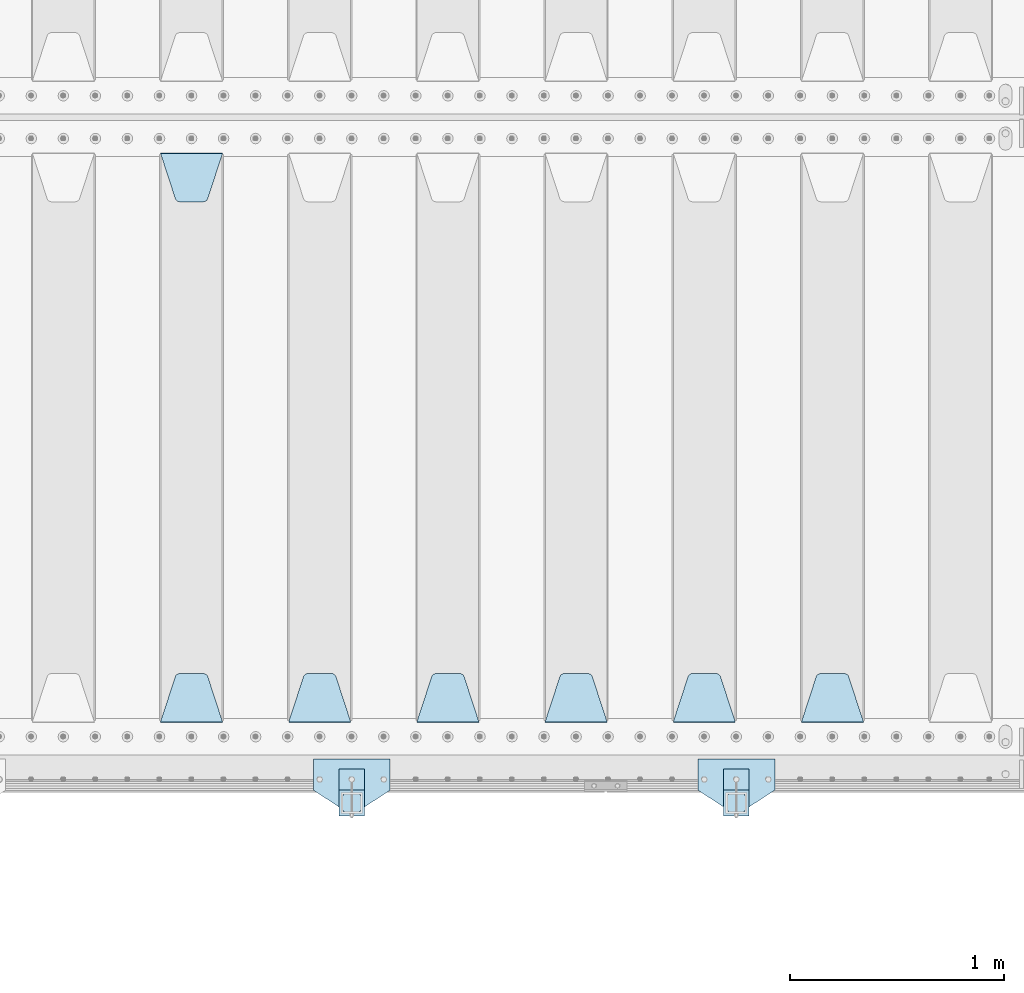
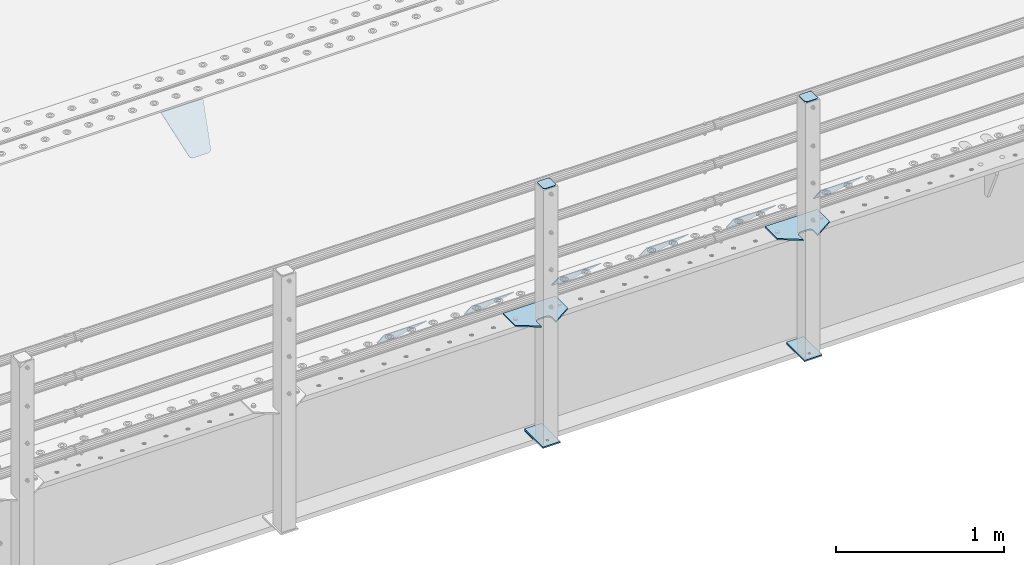
# One storey, part 197 of 242: 15 plates.
"""IFC2X3 building model written with IfcOpenShell, lengths in millimetres."""

from ifc_helpers import new_model, si_unit, frame, origin_with_axes, place, context, subcontext, project, spatial, faceted_brep, material, type_object, element, save


model = new_model("IFC2X3")

# Units and contexts
model_context = context("Model", 3, precision=1e-05, world=origin_with_axes())
body_context = subcontext(model_context, "Body", "Model", "MODEL_VIEW")
ifc_project = project(units=[si_unit("LENGTHUNIT", "METRE", prefix="MILLI"), si_unit("AREAUNIT", "SQUARE_METRE"), si_unit("VOLUMEUNIT", "CUBIC_METRE"), si_unit("MASSUNIT", "GRAM", prefix="KILO"), si_unit("TIMEUNIT", "SECOND"), si_unit("PLANEANGLEUNIT", "RADIAN"), si_unit("SOLIDANGLEUNIT", "STERADIAN"), si_unit("THERMODYNAMICTEMPERATUREUNIT", "DEGREE_CELSIUS"), si_unit("LUMINOUSINTENSITYUNIT", "LUMEN")], contexts=[model_context])

# Site, building, storey
site_placement = place(None, origin_with_axes())
site = spatial("IfcSite", under=ifc_project, at=site_placement, CompositionType="ELEMENT")
building_placement = place(site_placement, origin_with_axes())
building = spatial("IfcBuilding", under=site, at=building_placement, Name="Standard", CompositionType="ELEMENT")
storey_placement = place(building_placement, origin_with_axes())
storey = spatial("IfcBuildingStorey", under=building, at=storey_placement, Name="Undefined", CompositionType="ELEMENT", Elevation=0.0)

# Plates
ifc_material_1 = material(Name="STEEL/S355J2")
plate_type_1 = type_object("IfcPlateType", PredefinedType="NOTDEFINED")
plate_1_placement = place(storey_placement, frame((-36320.0, -24005.0, 5.00000000004911), z_axis=(0.0, -1.0, 0.0), x_axis=(-1.0, 0.0, 0.0)))
element("IfcPlate", 1, at=plate_1_placement, inside=storey, type_object=plate_type_1, material=ifc_material_1, context=body_context, shape_type="Brep", body=[
    faceted_brep([(0.0, -5.0, 0.0), (2.31396552408114e-06, -5.0, 145.0), (2.31396552408114e-06, 5.0, 145.0), (0.0, 5.0, 0.0), (130.0, -5.0, 230.0), (130.0, 5.0, 230.0), (130.0, -5.0, 180.0), (130.0, 5.0, 180.0), (130.48036798992, -5.0, 175.122741949595), (130.48036798992, 5.0, 175.122741949595), (131.903011687216, -5.0, 170.432914190871), (131.903011687216, 5.0, 170.432914190871), (134.213259692435, -5.0, 166.110744174512), (134.213259692435, 5.0, 166.110744174512), (137.322330470335, -5.0, 162.322330470335), (137.322330470335, 5.0, 162.322330470335), (141.110744174512, -5.0, 159.213259692435), (141.110744174512, 5.0, 159.213259692435), (145.432914190871, -5.0, 156.903011687216), (145.432914190871, 5.0, 156.903011687216), (150.122741949595, -5.0, 155.48036798992), (150.122741949595, 5.0, 155.48036798992), (155.0, -5.0, 155.0), (155.0, 5.0, 155.0), (205.0, -5.0, 155.0), (205.0, 5.0, 155.0), (209.877258050405, -5.0, 155.48036798992), (209.877258050405, 5.0, 155.48036798992), (214.567085809129, -5.0, 156.903011687216), (214.567085809129, 5.0, 156.903011687216), (218.889255825488, -5.0, 159.213259692435), (218.889255825488, 5.0, 159.213259692435), (222.677669529665, -5.0, 162.322330470335), (222.677669529665, 5.0, 162.322330470335), (225.786740307565, -5.0, 166.110744174512), (225.786740307565, 5.0, 166.110744174512), (228.096988312784, -5.0, 170.432914190871), (228.096988312784, 5.0, 170.432914190871), (229.51963201008, -5.0, 175.122741949595), (229.51963201008, 5.0, 175.122741949595), (230.0, -5.0, 180.0), (230.0, 5.0, 180.0), (230.0, -5.0, 230.0), (230.0, 5.0, 230.0), (360.0, -5.0, 145.0), (360.0, 5.0, 145.0), (360.0, -5.0, -7.27595761418343e-12), (360.0, 5.0, -7.27595761418343e-12)], [[[0, 1, 2, 3]], [[1, 4, 5, 2]], [[4, 6, 7, 5]], [[6, 8, 9, 7]], [[8, 10, 11, 9]], [[10, 12, 13, 11]], [[12, 14, 15, 13]], [[14, 16, 17, 15]], [[16, 18, 19, 17]], [[18, 20, 21, 19]], [[20, 22, 23, 21]], [[22, 24, 25, 23]], [[24, 26, 27, 25]], [[26, 28, 29, 27]], [[28, 30, 31, 29]], [[30, 32, 33, 31]], [[32, 34, 35, 33]], [[34, 36, 37, 35]], [[36, 38, 39, 37]], [[38, 40, 41, 39]], [[40, 42, 43, 41]], [[42, 44, 45, 43]], [[44, 46, 47, 45]], [[46, 0, 3, 47]], [[5, 7, 9, 11, 13, 15, 17, 19, 21, 23, 25, 27, 29, 31, 33, 35, 37, 39, 41, 43, 45, 47, 3, 2]], [[46, 44, 42, 40, 38, 36, 34, 32, 30, 28, 26, 24, 22, 20, 18, 16, 14, 12, 10, 8, 6, 4, 1, 0]]]),
])
plate_2_placement = place(storey_placement, frame((-38120.0, -24005.0, 5.00000000004911), z_axis=(0.0, -1.0, 0.0), x_axis=(-1.0, 0.0, 0.0)))
element("IfcPlate", 2, at=plate_2_placement, inside=storey, type_object=plate_type_1, material=ifc_material_1, context=body_context, shape_type="Brep", body=[
    faceted_brep([(0.0, -5.0, 0.0), (2.31396552408114e-06, -5.0, 145.0), (2.31396552408114e-06, 5.0, 145.0), (0.0, 5.0, 0.0), (130.0, -5.0, 230.0), (130.0, 5.0, 230.0), (130.0, -5.0, 180.0), (130.0, 5.0, 180.0), (130.48036798992, -5.0, 175.122741949595), (130.48036798992, 5.0, 175.122741949595), (131.903011687216, -5.0, 170.432914190871), (131.903011687216, 5.0, 170.432914190871), (134.213259692435, -5.0, 166.110744174512), (134.213259692435, 5.0, 166.110744174512), (137.322330470335, -5.0, 162.322330470335), (137.322330470335, 5.0, 162.322330470335), (141.110744174512, -5.0, 159.213259692435), (141.110744174512, 5.0, 159.213259692435), (145.432914190871, -5.0, 156.903011687216), (145.432914190871, 5.0, 156.903011687216), (150.122741949595, -5.0, 155.48036798992), (150.122741949595, 5.0, 155.48036798992), (155.0, -5.0, 155.0), (155.0, 5.0, 155.0), (205.0, -5.0, 155.0), (205.0, 5.0, 155.0), (209.877258050405, -5.0, 155.48036798992), (209.877258050405, 5.0, 155.48036798992), (214.567085809129, -5.0, 156.903011687216), (214.567085809129, 5.0, 156.903011687216), (218.889255825488, -5.0, 159.213259692435), (218.889255825488, 5.0, 159.213259692435), (222.677669529665, -5.0, 162.322330470335), (222.677669529665, 5.0, 162.322330470335), (225.786740307565, -5.0, 166.110744174512), (225.786740307565, 5.0, 166.110744174512), (228.096988312784, -5.0, 170.432914190871), (228.096988312784, 5.0, 170.432914190871), (229.51963201008, -5.0, 175.122741949595), (229.51963201008, 5.0, 175.122741949595), (230.0, -5.0, 180.0), (230.0, 5.0, 180.0), (230.0, -5.0, 230.0), (230.0, 5.0, 230.0), (360.0, -5.0, 145.0), (360.0, 5.0, 145.0), (360.0, -5.0, -7.27595761418343e-12), (360.0, 5.0, -7.27595761418343e-12)], [[[0, 1, 2, 3]], [[1, 4, 5, 2]], [[4, 6, 7, 5]], [[6, 8, 9, 7]], [[8, 10, 11, 9]], [[10, 12, 13, 11]], [[12, 14, 15, 13]], [[14, 16, 17, 15]], [[16, 18, 19, 17]], [[18, 20, 21, 19]], [[20, 22, 23, 21]], [[22, 24, 25, 23]], [[24, 26, 27, 25]], [[26, 28, 29, 27]], [[28, 30, 31, 29]], [[30, 32, 33, 31]], [[32, 34, 35, 33]], [[34, 36, 37, 35]], [[36, 38, 39, 37]], [[38, 40, 41, 39]], [[40, 42, 43, 41]], [[42, 44, 45, 43]], [[44, 46, 47, 45]], [[46, 0, 3, 47]], [[5, 7, 9, 11, 13, 15, 17, 19, 21, 23, 25, 27, 29, 31, 33, 35, 37, 39, 41, 43, 45, 47, 3, 2]], [[46, 44, 42, 40, 38, 36, 34, 32, 30, 28, 26, 24, 22, 20, 18, 16, 14, 12, 10, 8, 6, 4, 1, 0]]]),
])
plate_type_2 = type_object("IfcPlateType", PredefinedType="NOTDEFINED")
for number, where, z_axis, x_axis in (
    (3, (-36440.0000000001, -24050.0000000002, -850.000000000002), (0.0, -1.0, 0.0), (-1.0, 0.0, 0.0)),
    (4, (-38240.0000000001, -24050.0000000002, -850.000000000002), (0.0, -1.0, 0.0), (-1.0, 0.0, 0.0)),
):
    element("IfcPlate", number, at=place(storey_placement, frame(where, z_axis=z_axis, x_axis=x_axis)), inside=storey, type_object=plate_type_2, material=ifc_material_1, context=body_context, shape_type="Brep", body=[
        faceted_brep([(53.6360389691836, -5.0, 176.363961030471), (53.6360389691836, 5.0, 176.363961030471), (59.9999999998618, 5.0, 178.999999999793), (59.9999999998618, -5.0, 178.999999999793), (66.3639610305399, 5.0, 176.363961030471), (66.3639610305399, -5.0, 176.363961030471), (68.9999999998618, 5.0, 169.999999999793), (68.9999999998618, -5.0, 169.999999999793), (66.3639610305399, 5.0, 163.636038969114), (66.3639610305399, -5.0, 163.636038969114), (59.9999999998618, 5.0, 160.999999999793), (59.9999999998618, -5.0, 160.999999999793), (53.6360389691836, 5.0, 163.636038969114), (53.6360389691836, -5.0, 163.636038969114), (50.9999999998618, 5.0, 169.999999999793), (50.9999999998618, -5.0, 169.999999999793), (120.0, -5.0, 0.0), (120.0, -5.0, 220.0), (0.0, -5.0, 220.0), (0.0, -5.0, 0.0), (0.0, 5.0, 0.0), (120.0, 5.0, 0.0), (120.0, 5.0, 220.0), (0.0, 5.0, 220.0)], [[[0, 1, 2, 3]], [[3, 2, 4, 5]], [[5, 4, 6, 7]], [[7, 6, 8, 9]], [[9, 8, 10, 11]], [[11, 10, 12, 13]], [[13, 12, 14, 15]], [[15, 14, 1, 0]], [[16, 17, 18, 19], [3, 5, 7, 9, 11, 13, 15, 0]], [[16, 19, 20, 21]], [[17, 16, 21, 22]], [[18, 17, 22, 23]], [[19, 18, 23, 20]], [[22, 21, 20, 23], [10, 8, 6, 4, 2, 1, 14, 12]]]),
    ])
plate_type_3 = type_object("IfcPlateType", PredefinedType="NOTDEFINED")
plate_3_placement = place(storey_placement, frame((-36544.0000000001, -24166.0000000002, 1012.50000000001), z_axis=(0.0, -1.0, 0.0), x_axis=(1.0, 0.0, 0.0)))
element("IfcPlate", 5, at=plate_3_placement, inside=storey, type_object=plate_type_3, material=ifc_material_1, context=body_context, shape_type="Brep", body=[
    faceted_brep([(0.0, -2.5, 19.0), (0.0, -2.5, 69.0), (0.0, 2.5, 69.0), (0.0, 2.5, 19.0), (0.476369668544066, -2.5, 73.2278977451715), (0.476369668544066, 2.5, 73.2278977451715), (1.88159150985302, -2.5, 77.2437910432345), (1.88159150985302, 2.5, 77.2437910432345), (4.14520183310742, -2.5, 80.8463062353148), (4.14520183310742, 2.5, 80.8463062353148), (7.15369376468516, -2.5, 83.8547981668926), (7.15369376468516, 2.5, 83.8547981668926), (10.7562089567655, -2.5, 86.118408490147), (10.7562089567655, 2.5, 86.118408490147), (14.7721022548285, -2.5, 87.5236303314559), (14.7721022548285, 2.5, 87.5236303314559), (19.0, -2.5, 88.0), (19.0, 2.5, 88.0), (69.0, -2.5, 88.0), (69.0, 2.5, 88.0), (73.2278977451715, -2.5, 87.5236303314559), (73.2278977451715, 2.5, 87.5236303314559), (77.2437910432345, -2.5, 86.118408490147), (77.2437910432345, 2.5, 86.118408490147), (80.8463062353148, -2.5, 83.8547981668926), (80.8463062353148, 2.5, 83.8547981668926), (83.8547981668926, -2.5, 80.8463062353148), (83.8547981668926, 2.5, 80.8463062353148), (86.118408490147, -2.5, 77.2437910432345), (86.118408490147, 2.5, 77.2437910432345), (87.5236303314559, -2.5, 73.2278977451715), (87.5236303314559, 2.5, 73.2278977451715), (88.0, -2.5, 69.0), (88.0, 2.5, 69.0), (88.0, -2.5, 19.0), (88.0, 2.5, 19.0), (87.5236303314559, -2.5, 14.7721022548285), (87.5236303314559, 2.5, 14.7721022548285), (86.118408490147, -2.5, 10.7562089567655), (86.118408490147, 2.5, 10.7562089567655), (83.8547981668926, -2.5, 7.15369376468516), (83.8547981668926, 2.5, 7.15369376468516), (80.8463062353148, -2.5, 4.14520183310742), (80.8463062353148, 2.5, 4.14520183310742), (77.2437910432345, -2.5, 1.88159150985302), (77.2437910432345, 2.5, 1.88159150985302), (73.2278977451715, -2.5, 0.476369668544066), (73.2278977451715, 2.5, 0.476369668544066), (69.0, -2.5, 0.0), (69.0, 2.5, 0.0), (19.0, -2.5, 0.0), (19.0, 2.5, 0.0), (14.7721022548285, -2.5, 0.476369668544066), (14.7721022548285, 2.5, 0.476369668544066), (10.7562089567655, -2.5, 1.88159150985302), (10.7562089567655, 2.5, 1.88159150985302), (7.15369376468516, -2.5, 4.14520183310742), (7.15369376468516, 2.5, 4.14520183310742), (4.14520183310742, -2.5, 7.15369376468516), (4.14520183310742, 2.5, 7.15369376468516), (1.88159150985302, -2.5, 10.7562089567655), (1.88159150985302, 2.5, 10.7562089567655), (0.476369668544066, -2.5, 14.7721022548285), (0.476369668544066, 2.5, 14.7721022548285)], [[[0, 1, 2, 3]], [[1, 4, 5, 2]], [[4, 6, 7, 5]], [[6, 8, 9, 7]], [[8, 10, 11, 9]], [[10, 12, 13, 11]], [[12, 14, 15, 13]], [[14, 16, 17, 15]], [[16, 18, 19, 17]], [[18, 20, 21, 19]], [[20, 22, 23, 21]], [[22, 24, 25, 23]], [[24, 26, 27, 25]], [[26, 28, 29, 27]], [[28, 30, 31, 29]], [[30, 32, 33, 31]], [[32, 34, 35, 33]], [[34, 36, 37, 35]], [[36, 38, 39, 37]], [[38, 40, 41, 39]], [[40, 42, 43, 41]], [[42, 44, 45, 43]], [[44, 46, 47, 45]], [[46, 48, 49, 47]], [[48, 50, 51, 49]], [[50, 52, 53, 51]], [[52, 54, 55, 53]], [[54, 56, 57, 55]], [[56, 58, 59, 57]], [[58, 60, 61, 59]], [[60, 62, 63, 61]], [[62, 0, 3, 63]], [[5, 7, 9, 11, 13, 15, 17, 19, 21, 23, 25, 27, 29, 31, 33, 35, 37, 39, 41, 43, 45, 47, 49, 51, 53, 55, 57, 59, 61, 63, 3, 2]], [[62, 60, 58, 56, 54, 52, 50, 48, 46, 44, 42, 40, 38, 36, 34, 32, 30, 28, 26, 24, 22, 20, 18, 16, 14, 12, 10, 8, 6, 4, 1, 0]]]),
])
plate_4_placement = place(storey_placement, frame((-38344.0000000001, -24166.0000000002, 1012.50000000001), z_axis=(0.0, -1.0, 0.0), x_axis=(1.0, 0.0, 0.0)))
element("IfcPlate", 6, at=plate_4_placement, inside=storey, type_object=plate_type_3, material=ifc_material_1, context=body_context, shape_type="Brep", body=[
    faceted_brep([(0.0, -2.5, 19.0), (0.0, -2.5, 69.0), (0.0, 2.5, 69.0), (0.0, 2.5, 19.0), (0.476369668544066, -2.5, 73.2278977451715), (0.476369668544066, 2.5, 73.2278977451715), (1.88159150985302, -2.5, 77.2437910432345), (1.88159150985302, 2.5, 77.2437910432345), (4.14520183310742, -2.5, 80.8463062353148), (4.14520183310742, 2.5, 80.8463062353148), (7.15369376468516, -2.5, 83.8547981668926), (7.15369376468516, 2.5, 83.8547981668926), (10.7562089567655, -2.5, 86.118408490147), (10.7562089567655, 2.5, 86.118408490147), (14.7721022548285, -2.5, 87.5236303314559), (14.7721022548285, 2.5, 87.5236303314559), (19.0, -2.5, 88.0), (19.0, 2.5, 88.0), (69.0, -2.5, 88.0), (69.0, 2.5, 88.0), (73.2278977451715, -2.5, 87.5236303314559), (73.2278977451715, 2.5, 87.5236303314559), (77.2437910432345, -2.5, 86.118408490147), (77.2437910432345, 2.5, 86.118408490147), (80.8463062353148, -2.5, 83.8547981668926), (80.8463062353148, 2.5, 83.8547981668926), (83.8547981668926, -2.5, 80.8463062353148), (83.8547981668926, 2.5, 80.8463062353148), (86.118408490147, -2.5, 77.2437910432345), (86.118408490147, 2.5, 77.2437910432345), (87.5236303314559, -2.5, 73.2278977451715), (87.5236303314559, 2.5, 73.2278977451715), (88.0, -2.5, 69.0), (88.0, 2.5, 69.0), (88.0, -2.5, 19.0), (88.0, 2.5, 19.0), (87.5236303314559, -2.5, 14.7721022548285), (87.5236303314559, 2.5, 14.7721022548285), (86.118408490147, -2.5, 10.7562089567655), (86.118408490147, 2.5, 10.7562089567655), (83.8547981668926, -2.5, 7.15369376468516), (83.8547981668926, 2.5, 7.15369376468516), (80.8463062353148, -2.5, 4.14520183310742), (80.8463062353148, 2.5, 4.14520183310742), (77.2437910432345, -2.5, 1.88159150985302), (77.2437910432345, 2.5, 1.88159150985302), (73.2278977451715, -2.5, 0.476369668544066), (73.2278977451715, 2.5, 0.476369668544066), (69.0, -2.5, 0.0), (69.0, 2.5, 0.0), (19.0, -2.5, 0.0), (19.0, 2.5, 0.0), (14.7721022548285, -2.5, 0.476369668544066), (14.7721022548285, 2.5, 0.476369668544066), (10.7562089567655, -2.5, 1.88159150985302), (10.7562089567655, 2.5, 1.88159150985302), (7.15369376468516, -2.5, 4.14520183310742), (7.15369376468516, 2.5, 4.14520183310742), (4.14520183310742, -2.5, 7.15369376468516), (4.14520183310742, 2.5, 7.15369376468516), (1.88159150985302, -2.5, 10.7562089567655), (1.88159150985302, 2.5, 10.7562089567655), (0.476369668544066, -2.5, 14.7721022548285), (0.476369668544066, 2.5, 14.7721022548285)], [[[0, 1, 2, 3]], [[1, 4, 5, 2]], [[4, 6, 7, 5]], [[6, 8, 9, 7]], [[8, 10, 11, 9]], [[10, 12, 13, 11]], [[12, 14, 15, 13]], [[14, 16, 17, 15]], [[16, 18, 19, 17]], [[18, 20, 21, 19]], [[20, 22, 23, 21]], [[22, 24, 25, 23]], [[24, 26, 27, 25]], [[26, 28, 29, 27]], [[28, 30, 31, 29]], [[30, 32, 33, 31]], [[32, 34, 35, 33]], [[34, 36, 37, 35]], [[36, 38, 39, 37]], [[38, 40, 41, 39]], [[40, 42, 43, 41]], [[42, 44, 45, 43]], [[44, 46, 47, 45]], [[46, 48, 49, 47]], [[48, 50, 51, 49]], [[50, 52, 53, 51]], [[52, 54, 55, 53]], [[54, 56, 57, 55]], [[56, 58, 59, 57]], [[58, 60, 61, 59]], [[60, 62, 63, 61]], [[62, 0, 3, 63]], [[5, 7, 9, 11, 13, 15, 17, 19, 21, 23, 25, 27, 29, 31, 33, 35, 37, 39, 41, 43, 45, 47, 49, 51, 53, 55, 57, 59, 61, 63, 3, 2]], [[62, 60, 58, 56, 54, 52, 50, 48, 46, 44, 42, 40, 38, 36, 34, 32, 30, 28, 26, 24, 22, 20, 18, 16, 14, 12, 10, 8, 6, 4, 1, 0]]]),
])
plate_type_4 = type_object("IfcPlateType", PredefinedType="NOTDEFINED")
for number, where, z_axis, x_axis in (
    (7, (-36440.0000000001, -24050.0000000002, -857.500000000002), (0.0, -1.0, 0.0), (-1.0, 0.0, 0.0)),
    (8, (-38240.0000000001, -24050.0000000002, -857.500000000002), (0.0, -1.0, 0.0), (-1.0, 0.0, 0.0)),
):
    element("IfcPlate", number, at=place(storey_placement, frame(where, z_axis=z_axis, x_axis=x_axis)), inside=storey, type_object=plate_type_4, material=ifc_material_1, context=body_context, shape_type="Brep", body=[
        faceted_brep([(0.0, -2.5, 0.0), (0.0, -2.5, 100.0), (0.0, 2.5, 100.0), (0.0, 2.5, 0.0), (120.0, -2.5, 100.0), (120.0, 2.5, 100.0), (120.0, -2.5, 0.0), (120.0, 2.5, 0.0)], [[[0, 1, 2, 3]], [[1, 4, 5, 2]], [[4, 6, 7, 5]], [[6, 0, 3, 7]], [[5, 7, 3, 2]], [[6, 4, 1, 0]]]),
    ])
ifc_material_2 = material(Name="STEEL/S355N")
plate_type_5 = type_object("IfcPlateType", PredefinedType="NOTDEFINED")
plate_5_placement = place(storey_placement, frame((-35905.0, -23831.767766953, -1.76776695296758), z_axis=(0.0, 0.707106781186547, -0.707106781186548), x_axis=(-1.0, 0.0, 0.0)))
element("IfcPlate", 9, at=plate_5_placement, inside=storey, type_object=plate_type_5, material=ifc_material_2, context=body_context, shape_type="Brep", body=[
    faceted_brep([(0.0, -2.5, 0.0), (69.345504679477, -2.50000000000182, 300.171731424829), (69.345504679477, 2.5, 300.171731424829), (0.0, 2.5, 0.0), (70.9274061199576, -2.5, 304.897442415398), (70.9274061199576, 2.5, 304.897442415398), (73.3818627772307, -2.5, 309.234538108525), (73.3818627772307, 2.50000000000182, 309.234538108529), (76.6187032999551, -2.5, 313.023683126101), (76.6187032999551, 2.50000000000182, 313.023683126103), (80.5190132704993, -2.5, 316.12567259537), (80.5190132704993, 2.5, 316.12567259537), (84.9395038596849, -2.5, 318.426546230474), (84.9395038596849, 2.50000000000182, 318.426546230476), (89.7177759439219, -2.49999999999818, 319.841774983273), (89.7177759439219, 2.50000000000182, 319.841774983273), (94.678286292652, -2.5, 320.319366455076), (94.678286292652, 2.5, 320.319366455076), (195.321713707348, -2.5, 320.319366455076), (195.321713707348, 2.5, 320.319366455076), (200.282224056078, -2.5, 319.841774983272), (200.282224056078, 2.50000000000182, 319.841774983273), (205.060496140315, -2.5, 318.426546230474), (205.060496140315, 2.49999999999818, 318.426546230474), (209.480986729501, -2.49999999999818, 316.12567259537), (209.480986729501, 2.5, 316.12567259537), (213.381296700045, -2.5, 313.023683126101), (213.381296700045, 2.49999999999818, 313.023683126101), (216.618137222769, -2.5, 309.234538108525), (216.618137222769, 2.5, 309.234538108523), (219.072593880042, -2.49999999999818, 304.897442415398), (219.072593880042, 2.50000000000182, 304.897442415398), (220.654495320523, -2.50000000000182, 300.171731424829), (220.654495320523, 2.5, 300.171731424829), (290.0, -2.5, 0.0), (290.0, 2.5, -1.81898940354586e-12)], [[[0, 1, 2, 3]], [[1, 4, 5, 2]], [[4, 6, 7, 5]], [[6, 8, 9, 7]], [[8, 10, 11, 9]], [[10, 12, 13, 11]], [[12, 14, 15, 13]], [[14, 16, 17, 15]], [[16, 18, 19, 17]], [[18, 20, 21, 19]], [[20, 22, 23, 21]], [[22, 24, 25, 23]], [[24, 26, 27, 25]], [[26, 28, 29, 27]], [[28, 30, 31, 29]], [[30, 32, 33, 31]], [[32, 34, 35, 33]], [[34, 0, 3, 35]], [[5, 7, 9, 11, 13, 15, 17, 19, 21, 23, 25, 27, 29, 31, 33, 35, 3, 2]], [[34, 32, 30, 28, 26, 24, 22, 20, 18, 16, 14, 12, 10, 8, 6, 4, 1, 0]]]),
])
plate_6_placement = place(storey_placement, frame((-36505.0, -23831.767766953, -1.76776695296758), z_axis=(0.0, 0.707106781186547, -0.707106781186548), x_axis=(-1.0, 0.0, 0.0)))
element("IfcPlate", 10, at=plate_6_placement, inside=storey, type_object=plate_type_5, material=ifc_material_2, context=body_context, shape_type="Brep", body=[
    faceted_brep([(0.0, -2.5, 0.0), (69.345504679477, -2.50000000000182, 300.171731424829), (69.345504679477, 2.5, 300.171731424829), (0.0, 2.5, 0.0), (70.9274061199576, -2.5, 304.897442415398), (70.9274061199576, 2.5, 304.897442415398), (73.3818627772307, -2.5, 309.234538108525), (73.3818627772307, 2.50000000000182, 309.234538108529), (76.6187032999551, -2.5, 313.023683126101), (76.6187032999551, 2.50000000000182, 313.023683126103), (80.5190132704993, -2.5, 316.12567259537), (80.5190132704993, 2.5, 316.12567259537), (84.9395038596849, -2.5, 318.426546230474), (84.9395038596849, 2.50000000000182, 318.426546230476), (89.7177759439219, -2.49999999999818, 319.841774983273), (89.7177759439219, 2.50000000000182, 319.841774983273), (94.678286292652, -2.5, 320.319366455076), (94.678286292652, 2.5, 320.319366455076), (195.321713707348, -2.5, 320.319366455076), (195.321713707348, 2.5, 320.319366455076), (200.282224056078, -2.5, 319.841774983272), (200.282224056078, 2.50000000000182, 319.841774983273), (205.060496140315, -2.5, 318.426546230474), (205.060496140315, 2.49999999999818, 318.426546230474), (209.480986729501, -2.49999999999818, 316.12567259537), (209.480986729501, 2.5, 316.12567259537), (213.381296700045, -2.5, 313.023683126101), (213.381296700045, 2.49999999999818, 313.023683126101), (216.618137222769, -2.5, 309.234538108525), (216.618137222769, 2.5, 309.234538108523), (219.072593880042, -2.49999999999818, 304.897442415398), (219.072593880042, 2.50000000000182, 304.897442415398), (220.654495320523, -2.50000000000182, 300.171731424829), (220.654495320523, 2.5, 300.171731424829), (290.0, -2.5, 0.0), (290.0, 2.5, -1.81898940354586e-12)], [[[0, 1, 2, 3]], [[1, 4, 5, 2]], [[4, 6, 7, 5]], [[6, 8, 9, 7]], [[8, 10, 11, 9]], [[10, 12, 13, 11]], [[12, 14, 15, 13]], [[14, 16, 17, 15]], [[16, 18, 19, 17]], [[18, 20, 21, 19]], [[20, 22, 23, 21]], [[22, 24, 25, 23]], [[24, 26, 27, 25]], [[26, 28, 29, 27]], [[28, 30, 31, 29]], [[30, 32, 33, 31]], [[32, 34, 35, 33]], [[34, 0, 3, 35]], [[5, 7, 9, 11, 13, 15, 17, 19, 21, 23, 25, 27, 29, 31, 33, 35, 3, 2]], [[34, 32, 30, 28, 26, 24, 22, 20, 18, 16, 14, 12, 10, 8, 6, 4, 1, 0]]]),
])
plate_7_placement = place(storey_placement, frame((-37105.0, -23831.767766953, -1.76776695296758), z_axis=(0.0, 0.707106781186547, -0.707106781186548), x_axis=(-1.0, 0.0, 0.0)))
element("IfcPlate", 11, at=plate_7_placement, inside=storey, type_object=plate_type_5, material=ifc_material_2, context=body_context, shape_type="Brep", body=[
    faceted_brep([(0.0, -2.5, 0.0), (69.345504679477, -2.50000000000182, 300.171731424829), (69.345504679477, 2.5, 300.171731424829), (0.0, 2.5, 0.0), (70.9274061199576, -2.5, 304.897442415398), (70.9274061199576, 2.5, 304.897442415398), (73.3818627772307, -2.5, 309.234538108525), (73.3818627772307, 2.50000000000182, 309.234538108529), (76.6187032999551, -2.5, 313.023683126101), (76.6187032999551, 2.50000000000182, 313.023683126103), (80.5190132704993, -2.5, 316.12567259537), (80.5190132704993, 2.5, 316.12567259537), (84.9395038596849, -2.5, 318.426546230474), (84.9395038596849, 2.50000000000182, 318.426546230476), (89.7177759439219, -2.49999999999818, 319.841774983273), (89.7177759439219, 2.50000000000182, 319.841774983273), (94.678286292652, -2.5, 320.319366455076), (94.678286292652, 2.5, 320.319366455076), (195.321713707348, -2.5, 320.319366455076), (195.321713707348, 2.5, 320.319366455076), (200.282224056078, -2.5, 319.841774983272), (200.282224056078, 2.50000000000182, 319.841774983273), (205.060496140315, -2.5, 318.426546230474), (205.060496140315, 2.49999999999818, 318.426546230474), (209.480986729501, -2.49999999999818, 316.12567259537), (209.480986729501, 2.5, 316.12567259537), (213.381296700045, -2.5, 313.023683126101), (213.381296700045, 2.49999999999818, 313.023683126101), (216.618137222769, -2.5, 309.234538108525), (216.618137222769, 2.5, 309.234538108523), (219.072593880042, -2.49999999999818, 304.897442415398), (219.072593880042, 2.50000000000182, 304.897442415398), (220.654495320523, -2.50000000000182, 300.171731424829), (220.654495320523, 2.5, 300.171731424829), (290.0, -2.5, 0.0), (290.0, 2.5, -1.81898940354586e-12)], [[[0, 1, 2, 3]], [[1, 4, 5, 2]], [[4, 6, 7, 5]], [[6, 8, 9, 7]], [[8, 10, 11, 9]], [[10, 12, 13, 11]], [[12, 14, 15, 13]], [[14, 16, 17, 15]], [[16, 18, 19, 17]], [[18, 20, 21, 19]], [[20, 22, 23, 21]], [[22, 24, 25, 23]], [[24, 26, 27, 25]], [[26, 28, 29, 27]], [[28, 30, 31, 29]], [[30, 32, 33, 31]], [[32, 34, 35, 33]], [[34, 0, 3, 35]], [[5, 7, 9, 11, 13, 15, 17, 19, 21, 23, 25, 27, 29, 31, 33, 35, 3, 2]], [[34, 32, 30, 28, 26, 24, 22, 20, 18, 16, 14, 12, 10, 8, 6, 4, 1, 0]]]),
])
plate_8_placement = place(storey_placement, frame((-37705.0, -23831.767766953, -1.76776695296758), z_axis=(0.0, 0.707106781186547, -0.707106781186548), x_axis=(-1.0, 0.0, 0.0)))
element("IfcPlate", 12, at=plate_8_placement, inside=storey, type_object=plate_type_5, material=ifc_material_2, context=body_context, shape_type="Brep", body=[
    faceted_brep([(0.0, -2.5, 0.0), (69.345504679477, -2.50000000000182, 300.171731424829), (69.345504679477, 2.5, 300.171731424829), (0.0, 2.5, 0.0), (70.9274061199576, -2.5, 304.897442415398), (70.9274061199576, 2.5, 304.897442415398), (73.3818627772307, -2.5, 309.234538108525), (73.3818627772307, 2.50000000000182, 309.234538108529), (76.6187032999551, -2.5, 313.023683126101), (76.6187032999551, 2.50000000000182, 313.023683126103), (80.5190132704993, -2.5, 316.12567259537), (80.5190132704993, 2.5, 316.12567259537), (84.9395038596849, -2.5, 318.426546230474), (84.9395038596849, 2.50000000000182, 318.426546230476), (89.7177759439219, -2.49999999999818, 319.841774983273), (89.7177759439219, 2.50000000000182, 319.841774983273), (94.678286292652, -2.5, 320.319366455076), (94.678286292652, 2.5, 320.319366455076), (195.321713707348, -2.5, 320.319366455076), (195.321713707348, 2.5, 320.319366455076), (200.282224056078, -2.5, 319.841774983272), (200.282224056078, 2.50000000000182, 319.841774983273), (205.060496140315, -2.5, 318.426546230474), (205.060496140315, 2.49999999999818, 318.426546230474), (209.480986729501, -2.49999999999818, 316.12567259537), (209.480986729501, 2.5, 316.12567259537), (213.381296700045, -2.5, 313.023683126101), (213.381296700045, 2.49999999999818, 313.023683126101), (216.618137222769, -2.5, 309.234538108525), (216.618137222769, 2.5, 309.234538108523), (219.072593880042, -2.49999999999818, 304.897442415398), (219.072593880042, 2.50000000000182, 304.897442415398), (220.654495320523, -2.50000000000182, 300.171731424829), (220.654495320523, 2.5, 300.171731424829), (290.0, -2.5, 0.0), (290.0, 2.5, -1.81898940354586e-12)], [[[0, 1, 2, 3]], [[1, 4, 5, 2]], [[4, 6, 7, 5]], [[6, 8, 9, 7]], [[8, 10, 11, 9]], [[10, 12, 13, 11]], [[12, 14, 15, 13]], [[14, 16, 17, 15]], [[16, 18, 19, 17]], [[18, 20, 21, 19]], [[20, 22, 23, 21]], [[22, 24, 25, 23]], [[24, 26, 27, 25]], [[26, 28, 29, 27]], [[28, 30, 31, 29]], [[30, 32, 33, 31]], [[32, 34, 35, 33]], [[34, 0, 3, 35]], [[5, 7, 9, 11, 13, 15, 17, 19, 21, 23, 25, 27, 29, 31, 33, 35, 3, 2]], [[34, 32, 30, 28, 26, 24, 22, 20, 18, 16, 14, 12, 10, 8, 6, 4, 1, 0]]]),
])
plate_9_placement = place(storey_placement, frame((-38305.0, -23831.767766953, -1.76776695296758), z_axis=(0.0, 0.707106781186547, -0.707106781186548), x_axis=(-1.0, 0.0, 0.0)))
element("IfcPlate", 13, at=plate_9_placement, inside=storey, type_object=plate_type_5, material=ifc_material_2, context=body_context, shape_type="Brep", body=[
    faceted_brep([(0.0, -2.5, 0.0), (69.345504679477, -2.50000000000182, 300.171731424829), (69.345504679477, 2.5, 300.171731424829), (0.0, 2.5, 0.0), (70.9274061199576, -2.5, 304.897442415398), (70.9274061199576, 2.5, 304.897442415398), (73.3818627772307, -2.5, 309.234538108525), (73.3818627772307, 2.50000000000182, 309.234538108529), (76.6187032999551, -2.5, 313.023683126101), (76.6187032999551, 2.50000000000182, 313.023683126103), (80.5190132704993, -2.5, 316.12567259537), (80.5190132704993, 2.5, 316.12567259537), (84.9395038596849, -2.5, 318.426546230474), (84.9395038596849, 2.50000000000182, 318.426546230476), (89.7177759439219, -2.49999999999818, 319.841774983273), (89.7177759439219, 2.50000000000182, 319.841774983273), (94.678286292652, -2.5, 320.319366455076), (94.678286292652, 2.5, 320.319366455076), (195.321713707348, -2.5, 320.319366455076), (195.321713707348, 2.5, 320.319366455076), (200.282224056078, -2.5, 319.841774983272), (200.282224056078, 2.50000000000182, 319.841774983273), (205.060496140315, -2.5, 318.426546230474), (205.060496140315, 2.49999999999818, 318.426546230474), (209.480986729501, -2.49999999999818, 316.12567259537), (209.480986729501, 2.5, 316.12567259537), (213.381296700045, -2.5, 313.023683126101), (213.381296700045, 2.49999999999818, 313.023683126101), (216.618137222769, -2.5, 309.234538108525), (216.618137222769, 2.5, 309.234538108523), (219.072593880042, -2.49999999999818, 304.897442415398), (219.072593880042, 2.50000000000182, 304.897442415398), (220.654495320523, -2.50000000000182, 300.171731424829), (220.654495320523, 2.5, 300.171731424829), (290.0, -2.5, 0.0), (290.0, 2.5, -1.81898940354586e-12)], [[[0, 1, 2, 3]], [[1, 4, 5, 2]], [[4, 6, 7, 5]], [[6, 8, 9, 7]], [[8, 10, 11, 9]], [[10, 12, 13, 11]], [[12, 14, 15, 13]], [[14, 16, 17, 15]], [[16, 18, 19, 17]], [[18, 20, 21, 19]], [[20, 22, 23, 21]], [[22, 24, 25, 23]], [[24, 26, 27, 25]], [[26, 28, 29, 27]], [[28, 30, 31, 29]], [[30, 32, 33, 31]], [[32, 34, 35, 33]], [[34, 0, 3, 35]], [[5, 7, 9, 11, 13, 15, 17, 19, 21, 23, 25, 27, 29, 31, 33, 35, 3, 2]], [[34, 32, 30, 28, 26, 24, 22, 20, 18, 16, 14, 12, 10, 8, 6, 4, 1, 0]]]),
])
plate_10_placement = place(storey_placement, frame((-39195.0, -21168.232233044, -1.76776695296576), z_axis=(0.0, -0.707106781186547, -0.707106781186548), x_axis=(1.0, 0.0, 0.0)))
element("IfcPlate", 14, at=plate_10_placement, inside=storey, type_object=plate_type_5, material=ifc_material_2, context=body_context, shape_type="Brep", body=[
    faceted_brep([(0.0, -2.5, 0.0), (69.345504679477, -2.50000000000182, 300.171731424829), (69.345504679477, 2.5, 300.171731424829), (0.0, 2.5, 0.0), (70.9274061199576, -2.5, 304.897442415398), (70.9274061199576, 2.5, 304.897442415398), (73.3818627772307, -2.5, 309.234538108525), (73.3818627772307, 2.50000000000182, 309.234538108529), (76.6187032999551, -2.5, 313.023683126101), (76.6187032999551, 2.50000000000182, 313.023683126103), (80.5190132704993, -2.5, 316.12567259537), (80.5190132704993, 2.5, 316.12567259537), (84.9395038596849, -2.5, 318.426546230474), (84.9395038596849, 2.50000000000182, 318.426546230476), (89.7177759439219, -2.49999999999818, 319.841774983273), (89.7177759439219, 2.50000000000182, 319.841774983273), (94.678286292652, -2.5, 320.319366455076), (94.678286292652, 2.5, 320.319366455076), (195.321713707348, -2.5, 320.319366455076), (195.321713707348, 2.5, 320.319366455076), (200.282224056078, -2.5, 319.841774983272), (200.282224056078, 2.50000000000182, 319.841774983273), (205.060496140315, -2.5, 318.426546230474), (205.060496140315, 2.49999999999818, 318.426546230474), (209.480986729501, -2.49999999999818, 316.12567259537), (209.480986729501, 2.5, 316.12567259537), (213.381296700045, -2.5, 313.023683126101), (213.381296700045, 2.49999999999818, 313.023683126101), (216.618137222769, -2.5, 309.234538108525), (216.618137222769, 2.5, 309.234538108523), (219.072593880042, -2.49999999999818, 304.897442415398), (219.072593880042, 2.50000000000182, 304.897442415398), (220.654495320523, -2.50000000000182, 300.171731424829), (220.654495320523, 2.5, 300.171731424829), (290.0, -2.5, 0.0), (290.0, 2.5, -1.81898940354586e-12)], [[[0, 1, 2, 3]], [[1, 4, 5, 2]], [[4, 6, 7, 5]], [[6, 8, 9, 7]], [[8, 10, 11, 9]], [[10, 12, 13, 11]], [[12, 14, 15, 13]], [[14, 16, 17, 15]], [[16, 18, 19, 17]], [[18, 20, 21, 19]], [[20, 22, 23, 21]], [[22, 24, 25, 23]], [[24, 26, 27, 25]], [[26, 28, 29, 27]], [[28, 30, 31, 29]], [[30, 32, 33, 31]], [[32, 34, 35, 33]], [[34, 0, 3, 35]], [[5, 7, 9, 11, 13, 15, 17, 19, 21, 23, 25, 27, 29, 31, 33, 35, 3, 2]], [[34, 32, 30, 28, 26, 24, 22, 20, 18, 16, 14, 12, 10, 8, 6, 4, 1, 0]]]),
])
plate_11_placement = place(storey_placement, frame((-38905.0, -23831.767766953, -1.76776695296758), z_axis=(0.0, 0.707106781186547, -0.707106781186548), x_axis=(-1.0, 0.0, 0.0)))
element("IfcPlate", 15, at=plate_11_placement, inside=storey, type_object=plate_type_5, material=ifc_material_2, context=body_context, shape_type="Brep", body=[
    faceted_brep([(0.0, -2.5, 0.0), (69.345504679477, -2.50000000000182, 300.171731424829), (69.345504679477, 2.5, 300.171731424829), (0.0, 2.5, 0.0), (70.9274061199576, -2.5, 304.897442415398), (70.9274061199576, 2.5, 304.897442415398), (73.3818627772307, -2.5, 309.234538108525), (73.3818627772307, 2.50000000000182, 309.234538108529), (76.6187032999551, -2.5, 313.023683126101), (76.6187032999551, 2.50000000000182, 313.023683126103), (80.5190132704993, -2.5, 316.12567259537), (80.5190132704993, 2.5, 316.12567259537), (84.9395038596849, -2.5, 318.426546230474), (84.9395038596849, 2.50000000000182, 318.426546230476), (89.7177759439219, -2.49999999999818, 319.841774983273), (89.7177759439219, 2.50000000000182, 319.841774983273), (94.678286292652, -2.5, 320.319366455076), (94.678286292652, 2.5, 320.319366455076), (195.321713707348, -2.5, 320.319366455076), (195.321713707348, 2.5, 320.319366455076), (200.282224056078, -2.5, 319.841774983272), (200.282224056078, 2.50000000000182, 319.841774983273), (205.060496140315, -2.5, 318.426546230474), (205.060496140315, 2.49999999999818, 318.426546230474), (209.480986729501, -2.49999999999818, 316.12567259537), (209.480986729501, 2.5, 316.12567259537), (213.381296700045, -2.5, 313.023683126101), (213.381296700045, 2.49999999999818, 313.023683126101), (216.618137222769, -2.5, 309.234538108525), (216.618137222769, 2.5, 309.234538108523), (219.072593880042, -2.49999999999818, 304.897442415398), (219.072593880042, 2.50000000000182, 304.897442415398), (220.654495320523, -2.50000000000182, 300.171731424829), (220.654495320523, 2.5, 300.171731424829), (290.0, -2.5, 0.0), (290.0, 2.5, -1.81898940354586e-12)], [[[0, 1, 2, 3]], [[1, 4, 5, 2]], [[4, 6, 7, 5]], [[6, 8, 9, 7]], [[8, 10, 11, 9]], [[10, 12, 13, 11]], [[12, 14, 15, 13]], [[14, 16, 17, 15]], [[16, 18, 19, 17]], [[18, 20, 21, 19]], [[20, 22, 23, 21]], [[22, 24, 25, 23]], [[24, 26, 27, 25]], [[26, 28, 29, 27]], [[28, 30, 31, 29]], [[30, 32, 33, 31]], [[32, 34, 35, 33]], [[34, 0, 3, 35]], [[5, 7, 9, 11, 13, 15, 17, 19, 21, 23, 25, 27, 29, 31, 33, 35, 3, 2]], [[34, 32, 30, 28, 26, 24, 22, 20, 18, 16, 14, 12, 10, 8, 6, 4, 1, 0]]]),
])

save(model, "model.ifc")
